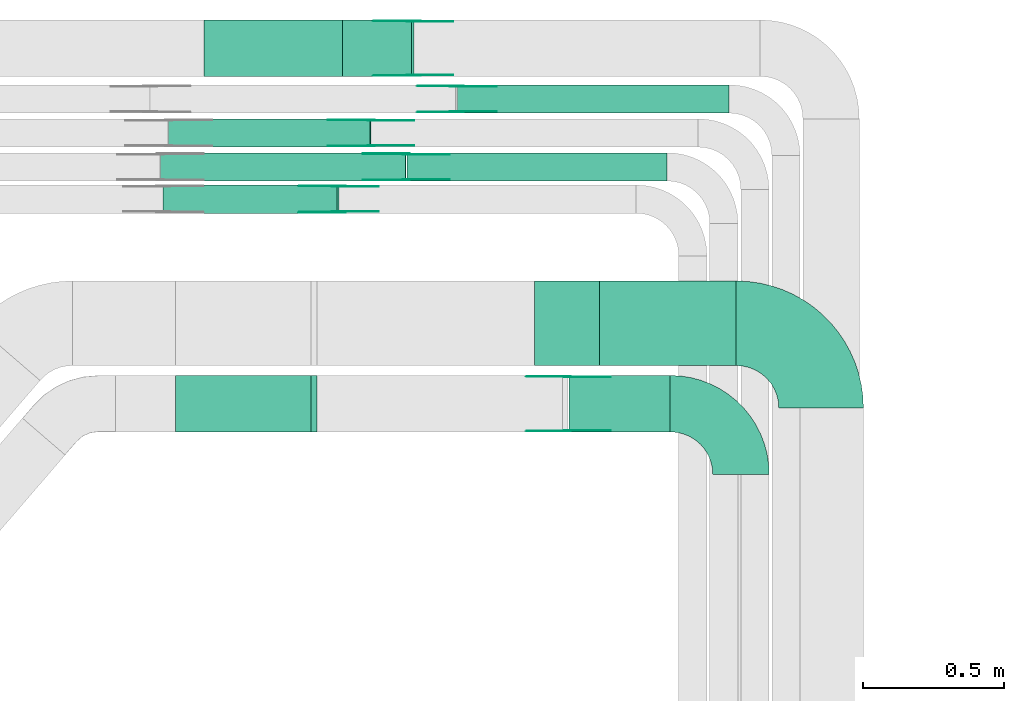
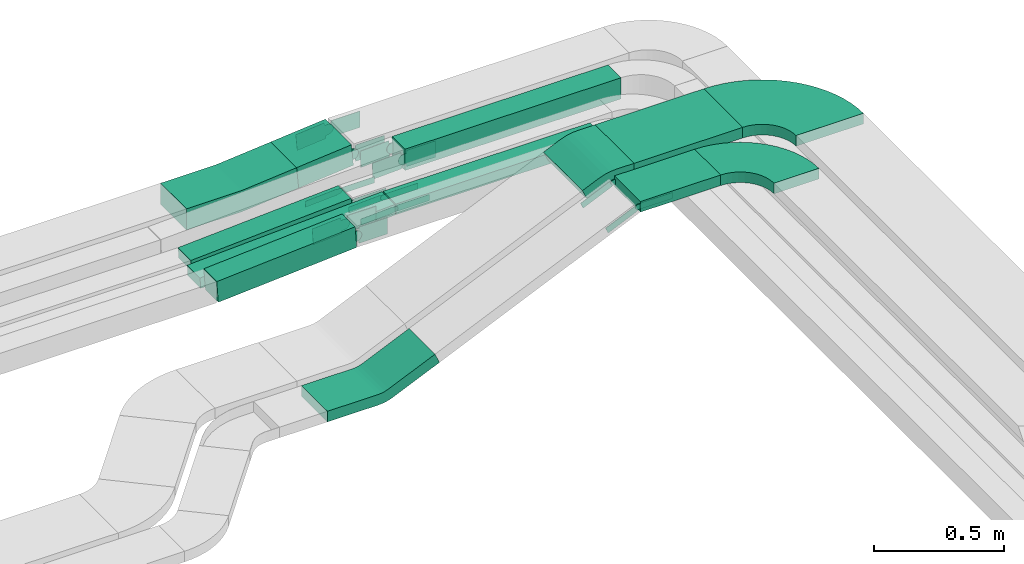
# One storey, part 21 of 28: 29 flow fittings, 8 flow segments.
"""IFC2X3 building model written with IfcOpenShell, lengths in millimetres."""

from ifc_helpers import new_model, entity, si_unit, converted_unit, derived_unit, direction, frame, frame_2d, origin, origin_2d_with_axis, place, context, subcontext, project, spatial, polyline, circle_curve, parameter, trimmed, segment, composite_curve, rectangle, outline, extrude, source, transform, mapped, material, type_object, type_shapes, element, save


model = new_model("IFC2X3")

# Units and contexts
model_context = context("Model", 3, precision=0.01, world=origin(), true_north=direction((6.12303176911189e-17, 1.0)))
body_context = subcontext(model_context, "Body", "Model", "MODEL_VIEW")
ifc_project = project(units=[si_unit("LENGTHUNIT", "METRE", prefix="MILLI"), si_unit("AREAUNIT", "SQUARE_METRE"), si_unit("VOLUMEUNIT", "CUBIC_METRE"), converted_unit("PLANEANGLEUNIT", "DEGREE", entity("IfcRatioMeasure", 0.0174532925199433), si_unit("PLANEANGLEUNIT", "RADIAN"), dimensions=[0, 0, 0, 0, 0, 0, 0]), si_unit("MASSUNIT", "GRAM", prefix="KILO"), derived_unit("MASSDENSITYUNIT", [(si_unit("MASSUNIT", "GRAM", prefix="KILO"), 1), (si_unit("LENGTHUNIT", "METRE"), -3)]), derived_unit("MOMENTOFINERTIAUNIT", [(si_unit("LENGTHUNIT", "METRE"), 4)]), si_unit("TIMEUNIT", "SECOND"), si_unit("FREQUENCYUNIT", "HERTZ"), si_unit("THERMODYNAMICTEMPERATUREUNIT", "DEGREE_CELSIUS"), derived_unit("THERMALTRANSMITTANCEUNIT", [(si_unit("MASSUNIT", "GRAM", prefix="KILO"), 1), (si_unit("THERMODYNAMICTEMPERATUREUNIT", "KELVIN"), -1), (si_unit("TIMEUNIT", "SECOND"), -3)]), derived_unit("VOLUMETRICFLOWRATEUNIT", [(si_unit("LENGTHUNIT", "METRE"), 3), (si_unit("TIMEUNIT", "SECOND"), -1)]), derived_unit("MASSFLOWRATEUNIT", [(si_unit("MASSUNIT", "GRAM", prefix="KILO"), 1), (si_unit("TIMEUNIT", "SECOND"), -1)]), derived_unit("ROTATIONALFREQUENCYUNIT", [(si_unit("TIMEUNIT", "SECOND"), -1)]), si_unit("ELECTRICCURRENTUNIT", "AMPERE"), si_unit("ELECTRICVOLTAGEUNIT", "VOLT"), si_unit("POWERUNIT", "WATT"), si_unit("FORCEUNIT", "NEWTON", prefix="KILO"), si_unit("ILLUMINANCEUNIT", "LUX"), si_unit("LUMINOUSFLUXUNIT", "LUMEN"), si_unit("LUMINOUSINTENSITYUNIT", "CANDELA"), derived_unit("USERDEFINED", [(si_unit("MASSUNIT", "GRAM", prefix="KILO"), -1), (si_unit("LENGTHUNIT", "METRE"), -2), (si_unit("TIMEUNIT", "SECOND"), 3), (si_unit("LUMINOUSFLUXUNIT", "LUMEN"), 1)]), derived_unit("LINEARVELOCITYUNIT", [(si_unit("LENGTHUNIT", "METRE"), 1), (si_unit("TIMEUNIT", "SECOND"), -1)]), si_unit("PRESSUREUNIT", "PASCAL"), derived_unit("USERDEFINED", [(si_unit("LENGTHUNIT", "METRE"), -2), (si_unit("MASSUNIT", "GRAM", prefix="KILO"), 1), (si_unit("TIMEUNIT", "SECOND"), -2)]), derived_unit("LINEARFORCEUNIT", [(si_unit("MASSUNIT", "GRAM", prefix="KILO"), 1), (si_unit("LENGTHUNIT", "METRE"), 1), (si_unit("TIMEUNIT", "SECOND"), -2), (si_unit("LENGTHUNIT", "METRE"), -1)]), derived_unit("PLANARFORCEUNIT", [(si_unit("MASSUNIT", "GRAM", prefix="KILO"), 1), (si_unit("LENGTHUNIT", "METRE"), 1), (si_unit("TIMEUNIT", "SECOND"), -2), (si_unit("LENGTHUNIT", "METRE"), -2)])], contexts=[model_context])

# Site, building, storey
site_placement = place(None, origin())
site = spatial("IfcSite", under=ifc_project, at=site_placement, CompositionType="ELEMENT")
building_placement = place(site_placement, origin())
building = spatial("IfcBuilding", under=site, at=building_placement, CompositionType="ELEMENT")
storey_placement = place(building_placement, frame((0.0, 0.0, 15900.0)))
storey = spatial("IfcBuildingStorey", under=building, at=storey_placement, CompositionType="ELEMENT", Elevation=15900.0)

# Flow segments
cable_carrier_segment_type = type_object("IfcCableCarrierSegmentType", PredefinedType="CABLETRAYSEGMENT")
flow_segment_1_placement = place(storey_placement, frame((59341.75, 15869.99, 2660.0)))
element("IfcFlowSegment", 1, at=flow_segment_1_placement, inside=storey, type_object=cable_carrier_segment_type, context=body_context, shape_type="SweptSolid", body=[
    extrude(rectangle(XDim=963.323442098033, YDim=99.9999999999989, at=origin_2d_with_axis()), frame((481.66, 50.0, 0.0), z_axis=(0.0, 0.0, 1.0), x_axis=(-1.0, 0.0, 0.0)), (0.0, 0.0, 1.0), 99.9999999999989),
])
flow_segment_2_placement = place(storey_placement, frame((59162.38, 15629.46, 2660.19)))
element("IfcFlowSegment", 2, at=flow_segment_2_placement, inside=storey, type_object=cable_carrier_segment_type, context=body_context, shape_type="SweptSolid", body=[
    extrude(rectangle(XDim=922.700351153026, YDim=99.9999999999989, at=origin_2d_with_axis()), frame((461.35, 50.0, 0.0), z_axis=(0.0, 0.0, 1.0), x_axis=(-1.0, 0.0, 0.0)), (0.0, 0.0, 1.0), 50.0000000000016),
])
flow_segment_3_placement = place(storey_placement, frame((58933.89, 15999.99, 2637.69)))
element("IfcFlowSegment", 3, at=flow_segment_3_placement, inside=storey, type_object=cable_carrier_segment_type, context=body_context, shape_type="SweptSolid", body=[
    extrude(rectangle(XDim=100.000000000003, YDim=200.000000000002, at=frame_2d((0.0, 0.0), x_axis=(0.0, 1.0))), frame((4.53, 100.0, 49.79), z_axis=(0.995891337468723, 0.0, 0.0905563026782642), x_axis=(0.0, 1.0, 0.0)), (0.0, 0.0, 1.0), 245.232289969506),
])
flow_segment_4_placement = place(storey_placement, frame((58297.9, 15514.99, 2617.34)))
element("IfcFlowSegment", 4, at=flow_segment_4_placement, inside=storey, type_object=cable_carrier_segment_type, context=body_context, shape_type="SweptSolid", body=[
    extrude(rectangle(XDim=100.0, YDim=99.9999999999989, at=origin_2d_with_axis()), frame((3.44, 50.0, 49.88), z_axis=(0.997626423978678, 0.0, 0.068858682673394), x_axis=(-0.068858682673394, 0.0, 0.997626423978678)), (0.0, 0.0, 1.0), 618.350729393012),
])
flow_segment_5_placement = place(storey_placement, frame((58318.19, 15749.46, 2617.52)))
element("IfcFlowSegment", 5, at=flow_segment_5_placement, inside=storey, type_object=cable_carrier_segment_type, context=body_context, shape_type="SweptSolid", body=[
    extrude(rectangle(XDim=50.0000000000018, YDim=99.9999999999989, at=frame_2d((0.0, 0.0), x_axis=(0.0, 1.0))), frame((1.49, 50.0, 24.96), z_axis=(0.998226574623021, 0.0, 0.0595290325504308), x_axis=(0.0, 1.0, 0.0)), (0.0, 0.0, 1.0), 715.803609284785),
])
flow_segment_6_placement = place(storey_placement, frame((58289.55, 15629.46, 2617.48)))
element("IfcFlowSegment", 6, at=flow_segment_6_placement, inside=storey, type_object=cable_carrier_segment_type, context=body_context, shape_type="SweptSolid", body=[
    extrude(rectangle(XDim=49.9999999999996, YDim=99.9999999999989, at=frame_2d((0.0, 0.0), x_axis=(0.0, 1.0))), frame((1.23, 50.0, 24.97), z_axis=(0.998794992173113, 0.0, 0.0490771190058262), x_axis=(0.0, 1.0, 0.0)), (0.0, 0.0, 1.0), 869.220832372037),
])
flow_segment_7_placement = place(storey_placement, frame((59737.94, 14740.03, 3010.0)))
element("IfcFlowSegment", 7, at=flow_segment_7_placement, inside=storey, type_object=cable_carrier_segment_type, context=body_context, shape_type="SweptSolid", body=[
    extrude(rectangle(XDim=357.878829425625, YDim=199.999999999998, at=origin_2d_with_axis()), frame((178.94, 100.0, 0.0), z_axis=(0.0, 0.0, 1.0), x_axis=(-1.0, 0.0, 0.0)), (0.0, 0.0, 1.0), 50.0000000000016),
])
flow_segment_8_placement = place(storey_placement, frame((59845.66, 14975.03, 3010.0)))
element("IfcFlowSegment", 8, at=flow_segment_8_placement, inside=storey, type_object=cable_carrier_segment_type, context=body_context, shape_type="SweptSolid", body=[
    extrude(rectangle(XDim=484.15332319662, YDim=300.000000000001, at=origin_2d_with_axis()), frame((242.08, 150.0, 0.0), z_axis=(0.0, 0.0, 1.0), x_axis=(-1.0, 0.0, 0.0)), (0.0, 0.0, 1.0), 50.0000000000016),
])

# Flow fittings
ifc_material_1 = material()
cable_carrier_fitting_type_1 = type_object("IfcCableCarrierFittingType", Name="470_DKC_S5_Variable Angle Elbow 0-45:-", PredefinedType="NOTDEFINED", material=ifc_material_1)
shared_shape_1 = source(origin(), body_context, "Body", "SweptSolid", [
    extrude(outline(composite_curve([segment(polyline([(-150.75, -300.25), (-149.75, -300.25)]), True, "CONTINUOUS"), segment(trimmed(circle_curve(frame_2d((-149.75, 149.75), x_axis=(0.0, -1.0)), 450.0), [parameter(0.0)], [parameter(90.0000000000001)], True, "PARAMETER"), True, "CONTINUOUS"), segment(polyline([(300.25, 149.75), (300.25, 150.75)]), True, "CONTINUOUS"), segment(polyline([(300.25, 150.75), (0.25, 150.75)]), True, "CONTINUOUS"), segment(polyline([(0.25, 150.75), (0.25, 149.75)]), True, "CONTINUOUS"), segment(trimmed(circle_curve(frame_2d((-149.75, 149.75), x_axis=(0.0, -1.0)), 150.0), [parameter(0.0)], [parameter(90.0000000000001)], True, "PARAMETER"), False, "CONTINUOUS"), segment(polyline([(-149.75, -0.25), (-150.75, -0.25)]), True, "CONTINUOUS"), segment(polyline([(-150.75, -0.25), (-150.75, -300.25)]), True, "CONTINUOUS")], self_intersect=False)), frame((-150.25, 150.25, -25.0)), (0.0, 0.0, 1.0), 49.9999999999974),
])
type_shapes(cable_carrier_fitting_type_1, [shared_shape_1])
flow_fitting_1_placement = place(storey_placement, frame((60630.82, 15125.03, 3035.0), z_axis=(0.0, 0.0, 1.0), x_axis=(0.0, 1.0, 0.0)))
element("IfcFlowFitting", 9, at=flow_fitting_1_placement, inside=storey, type_object=cable_carrier_fitting_type_1, material=ifc_material_1, Name="470_DKC_S5_Variable Angle Elbow 0-45:-", ObjectType="470_DKC_S5_Variable Angle Elbow 0-45:-", context=body_context, shape_type="MappedRepresentation", body=[
    mapped(shared_shape_1, transform((0.0, 0.0, 0.0), scale=1.0)),
])
ifc_material_2 = material(Name="G")
cable_carrier_fitting_type_2 = type_object("IfcCableCarrierFittingType", PredefinedType="NOTDEFINED", material=ifc_material_2)
shared_shape_2 = source(origin(), body_context, "Body", "SweptSolid", [
    extrude(outline(composite_curve([segment(trimmed(circle_curve(frame_2d((-44.59, 0.0), x_axis=(1.0, 0.0)), 12.5), [parameter(90.0000000000007)], [parameter(270.0)], True, "PARAMETER"), True, "CONTINUOUS"), segment(polyline([(-44.59, -12.5), (-33.09, -12.5)]), True, "CONTINUOUS"), segment(polyline([(-33.09, -12.5), (-31.23, -14.5)]), True, "CONTINUOUS"), segment(polyline([(-31.23, -14.5), (108.91, -14.5)]), True, "CONTINUOUS"), segment(polyline([(108.91, -14.5), (108.91, 14.5)]), True, "CONTINUOUS"), segment(polyline([(108.91, 14.5), (-31.23, 14.5)]), True, "CONTINUOUS"), segment(polyline([(-31.23, 14.5), (-33.09, 12.5)]), True, "CONTINUOUS"), segment(polyline([(-33.09, 12.5), (-44.59, 12.5)]), True, "CONTINUOUS")], self_intersect=False)), frame((44.59, 0.0, 0.0), z_axis=(0.0, 0.0, -1.0), x_axis=(1.0, 0.0, 0.0)), (0.0, 0.0, -1.0), 2.0),
])
type_shapes(cable_carrier_fitting_type_2, [shared_shape_2])
flow_fitting_2_placement = place(storey_placement, frame((59036.08, 15754.0, 2685.2), z_axis=(0.0, -1.0, 0.0), x_axis=(-0.998226574623013, 0.0, -0.0595290325505655)))
element("IfcFlowFitting", 10, at=flow_fitting_2_placement, inside=storey, type_object=cable_carrier_fitting_type_2, material=ifc_material_2, context=body_context, shape_type="MappedRepresentation", body=[
    mapped(shared_shape_2, transform((0.0, 0.0, 0.0), scale=1.0)),
])
cable_carrier_fitting_type_3 = type_object("IfcCableCarrierFittingType", PredefinedType="NOTDEFINED", material=ifc_material_2)
type_shapes(cable_carrier_fitting_type_3, [shared_shape_2])
flow_fitting_3_placement = place(storey_placement, frame((59036.08, 15842.92, 2685.2), z_axis=(0.0, 1.0, 0.0), x_axis=(1.0, 0.0, 0.0)))
element("IfcFlowFitting", 11, at=flow_fitting_3_placement, inside=storey, type_object=cable_carrier_fitting_type_3, material=ifc_material_2, context=body_context, shape_type="MappedRepresentation", body=[
    mapped(shared_shape_2, transform((0.0, 0.0, 0.0), scale=1.0)),
])
flow_fitting_4_placement = place(storey_placement, frame((59160.66, 15634.0, 2685.19), z_axis=(0.0, -1.0, 0.0), x_axis=(-0.998794992173109, 0.0, -0.0490771190058922)))
element("IfcFlowFitting", 12, at=flow_fitting_4_placement, inside=storey, type_object=cable_carrier_fitting_type_2, material=ifc_material_2, context=body_context, shape_type="MappedRepresentation", body=[
    mapped(shared_shape_2, transform((0.0, 0.0, 0.0), scale=1.0)),
])
flow_fitting_5_placement = place(storey_placement, frame((59160.66, 15722.92, 2685.19), z_axis=(0.0, 1.0, 0.0), x_axis=(1.0, 0.0, 0.0)))
element("IfcFlowFitting", 13, at=flow_fitting_5_placement, inside=storey, type_object=cable_carrier_fitting_type_3, material=ifc_material_2, context=body_context, shape_type="MappedRepresentation", body=[
    mapped(shared_shape_2, transform((0.0, 0.0, 0.0), scale=1.0)),
])
flow_fitting_6_placement = place(storey_placement, frame((59730.82, 14744.57, 3035.0), z_axis=(0.0, -1.0, 0.0), x_axis=(-0.914695360334433, 0.0, -0.404144030987297)))
element("IfcFlowFitting", 14, at=flow_fitting_6_placement, inside=storey, type_object=cable_carrier_fitting_type_2, material=ifc_material_2, context=body_context, shape_type="MappedRepresentation", body=[
    mapped(shared_shape_2, transform((0.0, 0.0, 0.0), scale=1.0)),
])
flow_fitting_7_placement = place(storey_placement, frame((59730.82, 14933.49, 3035.0), z_axis=(0.0, 1.0, 0.0), x_axis=(1.0, 0.0, 0.0)))
element("IfcFlowFitting", 15, at=flow_fitting_7_placement, inside=storey, type_object=cable_carrier_fitting_type_3, material=ifc_material_2, context=body_context, shape_type="MappedRepresentation", body=[
    mapped(shared_shape_2, transform((0.0, 0.0, 0.0), scale=1.0)),
])
cable_carrier_fitting_type_4 = type_object("IfcCableCarrierFittingType", PredefinedType="NOTDEFINED", material=ifc_material_2)
shared_shape_3 = source(origin(), body_context, "Body", "SweptSolid", [
    extrude(outline(composite_curve([segment(trimmed(circle_curve(frame_2d((-44.59, 0.0), x_axis=(1.0, 0.0)), 12.5), [parameter(90.0000000000007)], [parameter(270.0)], True, "PARAMETER"), True, "CONTINUOUS"), segment(polyline([(-44.59, -12.5), (-33.09, -12.5)]), True, "CONTINUOUS"), segment(polyline([(-33.09, -12.5), (-31.23, -14.5)]), True, "CONTINUOUS"), segment(polyline([(-31.23, -14.5), (108.91, -14.5)]), True, "CONTINUOUS"), segment(polyline([(108.91, -14.5), (108.91, 14.5)]), True, "CONTINUOUS"), segment(polyline([(108.91, 14.5), (-31.23, 14.5)]), True, "CONTINUOUS"), segment(polyline([(-31.23, 14.5), (-33.09, 12.5)]), True, "CONTINUOUS"), segment(polyline([(-33.09, 12.5), (-44.59, 12.5)]), True, "CONTINUOUS")], self_intersect=False)), frame((44.59, 0.0, 0.0)), (0.0, 0.0, 1.0), 2.0),
])
type_shapes(cable_carrier_fitting_type_4, [shared_shape_3])
flow_fitting_8_placement = place(storey_placement, frame((59036.08, 15844.92, 2685.2), z_axis=(0.0, 1.0, 0.0), x_axis=(-0.998226574623013, 0.0, -0.0595290325505655)))
element("IfcFlowFitting", 16, at=flow_fitting_8_placement, inside=storey, type_object=cable_carrier_fitting_type_4, material=ifc_material_2, context=body_context, shape_type="MappedRepresentation", body=[
    mapped(shared_shape_3, transform((0.0, 0.0, 0.0), scale=1.0)),
])
cable_carrier_fitting_type_5 = type_object("IfcCableCarrierFittingType", PredefinedType="NOTDEFINED", material=ifc_material_2)
type_shapes(cable_carrier_fitting_type_5, [shared_shape_3])
flow_fitting_9_placement = place(storey_placement, frame((59036.08, 15756.0, 2685.2), z_axis=(0.0, -1.0, 0.0), x_axis=(1.0, 0.0, 0.0)))
element("IfcFlowFitting", 17, at=flow_fitting_9_placement, inside=storey, type_object=cable_carrier_fitting_type_5, material=ifc_material_2, context=body_context, shape_type="MappedRepresentation", body=[
    mapped(shared_shape_3, transform((0.0, 0.0, 0.0), scale=1.0)),
])
flow_fitting_10_placement = place(storey_placement, frame((59160.66, 15724.92, 2685.19), z_axis=(0.0, 1.0, 0.0), x_axis=(-0.998794992173109, 0.0, -0.0490771190058922)))
element("IfcFlowFitting", 18, at=flow_fitting_10_placement, inside=storey, type_object=cable_carrier_fitting_type_4, material=ifc_material_2, context=body_context, shape_type="MappedRepresentation", body=[
    mapped(shared_shape_3, transform((0.0, 0.0, 0.0), scale=1.0)),
])
flow_fitting_11_placement = place(storey_placement, frame((59160.66, 15636.0, 2685.19), z_axis=(0.0, -1.0, 0.0), x_axis=(1.0, 0.0, 0.0)))
element("IfcFlowFitting", 19, at=flow_fitting_11_placement, inside=storey, type_object=cable_carrier_fitting_type_5, material=ifc_material_2, context=body_context, shape_type="MappedRepresentation", body=[
    mapped(shared_shape_3, transform((0.0, 0.0, 0.0), scale=1.0)),
])
flow_fitting_12_placement = place(storey_placement, frame((59730.82, 14935.49, 3035.0), z_axis=(0.0, 1.0, 0.0), x_axis=(-0.914695360334433, 0.0, -0.404144030987297)))
element("IfcFlowFitting", 20, at=flow_fitting_12_placement, inside=storey, type_object=cable_carrier_fitting_type_4, material=ifc_material_2, context=body_context, shape_type="MappedRepresentation", body=[
    mapped(shared_shape_3, transform((0.0, 0.0, 0.0), scale=1.0)),
])
flow_fitting_13_placement = place(storey_placement, frame((59730.82, 14746.57, 3035.0), z_axis=(0.0, -1.0, 0.0), x_axis=(1.0, 0.0, 0.0)))
element("IfcFlowFitting", 21, at=flow_fitting_13_placement, inside=storey, type_object=cable_carrier_fitting_type_5, material=ifc_material_2, context=body_context, shape_type="MappedRepresentation", body=[
    mapped(shared_shape_3, transform((0.0, 0.0, 0.0), scale=1.0)),
])
cable_carrier_fitting_type_6 = type_object("IfcCableCarrierFittingType", Name="470_DKC_S5_Variable Angle Elbow 0-45:-", PredefinedType="NOTDEFINED", material=ifc_material_1)
shared_shape_4 = source(origin(), body_context, "Body", "SweptSolid", [
    extrude(outline(composite_curve([segment(polyline([(-125.75, -225.25), (-124.75, -225.25)]), True, "CONTINUOUS"), segment(trimmed(circle_curve(frame_2d((-124.75, 124.75), x_axis=(0.0, -1.0)), 350.0), [parameter(0.0)], [parameter(90.0)], True, "PARAMETER"), True, "CONTINUOUS"), segment(polyline([(225.25, 124.75), (225.25, 125.75)]), True, "CONTINUOUS"), segment(polyline([(225.25, 125.75), (25.25, 125.75)]), True, "CONTINUOUS"), segment(polyline([(25.25, 125.75), (25.25, 124.75)]), True, "CONTINUOUS"), segment(trimmed(circle_curve(frame_2d((-124.75, 124.75), x_axis=(0.0, -1.0)), 150.0), [parameter(0.0)], [parameter(90.0)], True, "PARAMETER"), False, "CONTINUOUS"), segment(polyline([(-124.75, -25.25), (-125.75, -25.25)]), True, "CONTINUOUS"), segment(polyline([(-125.75, -25.25), (-125.75, -225.25)]), True, "CONTINUOUS")], self_intersect=False)), frame((-125.25, 125.25, -25.0)), (0.0, 0.0, 1.0), 50.000000000001),
])
type_shapes(cable_carrier_fitting_type_6, [shared_shape_4])
flow_fitting_14_placement = place(storey_placement, frame((60346.82, 14840.03, 3035.0), z_axis=(0.0, 0.0, 1.0), x_axis=(0.0, 1.0, 0.0)))
element("IfcFlowFitting", 22, at=flow_fitting_14_placement, inside=storey, type_object=cable_carrier_fitting_type_6, material=ifc_material_1, Name="470_DKC_S5_Variable Angle Elbow 0-45:-", ObjectType="470_DKC_S5_Variable Angle Elbow 0-45:-", context=body_context, shape_type="MappedRepresentation", body=[
    mapped(shared_shape_4, transform((0.0, 0.0, 0.0), scale=1.0)),
])
cable_carrier_fitting_type_7 = type_object("IfcCableCarrierFittingType", PredefinedType="NOTDEFINED", material=ifc_material_2)
shared_shape_5 = source(origin(), body_context, "Body", "SweptSolid", [
    extrude(outline(composite_curve([segment(trimmed(circle_curve(frame_2d((-41.47, 0.0), x_axis=(1.0, 0.0)), 25.0), [parameter(90.0000000000007)], [parameter(270.0)], True, "PARAMETER"), True, "CONTINUOUS"), segment(polyline([(-41.47, -25.0), (-29.97, -25.0)]), True, "CONTINUOUS"), segment(polyline([(-29.97, -25.0), (-28.1, -38.5)]), True, "CONTINUOUS"), segment(polyline([(-28.1, -38.5), (99.53, -38.5)]), True, "CONTINUOUS"), segment(polyline([(99.53, -38.5), (99.53, 38.5)]), True, "CONTINUOUS"), segment(polyline([(99.53, 38.5), (-28.1, 38.5)]), True, "CONTINUOUS"), segment(polyline([(-28.1, 38.5), (-29.97, 25.0)]), True, "CONTINUOUS"), segment(polyline([(-29.97, 25.0), (-41.47, 25.0)]), True, "CONTINUOUS")], self_intersect=False)), frame((41.47, 0.0, 0.0), z_axis=(0.0, 0.0, -1.0), x_axis=(1.0, 0.0, 0.0)), (0.0, 0.0, -1.0), 2.0),
])
type_shapes(cable_carrier_fitting_type_7, [shared_shape_5])
flow_fitting_15_placement = place(storey_placement, frame((58921.08, 15519.53, 2710.0), z_axis=(0.0, -1.0, 0.0), x_axis=(-0.997626423978682, 0.0, -0.0688586826733382)))
element("IfcFlowFitting", 23, at=flow_fitting_15_placement, inside=storey, type_object=cable_carrier_fitting_type_7, material=ifc_material_2, context=body_context, shape_type="MappedRepresentation", body=[
    mapped(shared_shape_5, transform((0.0, 0.0, 0.0), scale=1.0)),
])
cable_carrier_fitting_type_8 = type_object("IfcCableCarrierFittingType", PredefinedType="NOTDEFINED", material=ifc_material_2)
type_shapes(cable_carrier_fitting_type_8, [shared_shape_5])
flow_fitting_16_placement = place(storey_placement, frame((58921.08, 15608.45, 2710.0), z_axis=(0.0, 1.0, 0.0), x_axis=(1.0, 0.0, 0.0)))
element("IfcFlowFitting", 24, at=flow_fitting_16_placement, inside=storey, type_object=cable_carrier_fitting_type_8, material=ifc_material_2, context=body_context, shape_type="MappedRepresentation", body=[
    mapped(shared_shape_5, transform((0.0, 0.0, 0.0), scale=1.0)),
])
flow_fitting_17_placement = place(storey_placement, frame((59339.64, 15874.53, 2710.0), z_axis=(0.0, -1.0, 0.0), x_axis=(-0.999143050018218, 0.0, -0.0413904046886741)))
element("IfcFlowFitting", 25, at=flow_fitting_17_placement, inside=storey, type_object=cable_carrier_fitting_type_7, material=ifc_material_2, context=body_context, shape_type="MappedRepresentation", body=[
    mapped(shared_shape_5, transform((0.0, 0.0, 0.0), scale=1.0)),
])
flow_fitting_18_placement = place(storey_placement, frame((59339.64, 15963.45, 2710.0), z_axis=(0.0, 1.0, 0.0), x_axis=(1.0, 0.0, 0.0)))
element("IfcFlowFitting", 26, at=flow_fitting_18_placement, inside=storey, type_object=cable_carrier_fitting_type_8, material=ifc_material_2, context=body_context, shape_type="MappedRepresentation", body=[
    mapped(shared_shape_5, transform((0.0, 0.0, 0.0), scale=1.0)),
])
flow_fitting_19_placement = place(storey_placement, frame((59186.08, 16004.53, 2710.0), z_axis=(0.0, -1.0, 0.0), x_axis=(-0.995891337468728, 0.0, -0.0905563026782111)))
element("IfcFlowFitting", 27, at=flow_fitting_19_placement, inside=storey, type_object=cable_carrier_fitting_type_7, material=ifc_material_2, context=body_context, shape_type="MappedRepresentation", body=[
    mapped(shared_shape_5, transform((0.0, 0.0, 0.0), scale=1.0)),
])
flow_fitting_20_placement = place(storey_placement, frame((59186.08, 16193.45, 2710.0), z_axis=(0.0, 1.0, 0.0), x_axis=(1.0, 0.0, 0.0)))
element("IfcFlowFitting", 28, at=flow_fitting_20_placement, inside=storey, type_object=cable_carrier_fitting_type_8, material=ifc_material_2, context=body_context, shape_type="MappedRepresentation", body=[
    mapped(shared_shape_5, transform((0.0, 0.0, 0.0), scale=1.0)),
])
cable_carrier_fitting_type_9 = type_object("IfcCableCarrierFittingType", PredefinedType="NOTDEFINED", material=ifc_material_2)
shared_shape_6 = source(origin(), body_context, "Body", "SweptSolid", [
    extrude(outline(composite_curve([segment(trimmed(circle_curve(frame_2d((-41.47, 0.0), x_axis=(1.0, 0.0)), 25.0), [parameter(90.0000000000007)], [parameter(270.0)], True, "PARAMETER"), True, "CONTINUOUS"), segment(polyline([(-41.47, -25.0), (-29.97, -25.0)]), True, "CONTINUOUS"), segment(polyline([(-29.97, -25.0), (-28.1, -38.5)]), True, "CONTINUOUS"), segment(polyline([(-28.1, -38.5), (99.53, -38.5)]), True, "CONTINUOUS"), segment(polyline([(99.53, -38.5), (99.53, 38.5)]), True, "CONTINUOUS"), segment(polyline([(99.53, 38.5), (-28.1, 38.5)]), True, "CONTINUOUS"), segment(polyline([(-28.1, 38.5), (-29.97, 25.0)]), True, "CONTINUOUS"), segment(polyline([(-29.97, 25.0), (-41.47, 25.0)]), True, "CONTINUOUS")], self_intersect=False)), frame((41.47, 0.0, 0.0)), (0.0, 0.0, 1.0), 2.0),
])
type_shapes(cable_carrier_fitting_type_9, [shared_shape_6])
flow_fitting_21_placement = place(storey_placement, frame((58921.08, 15610.45, 2710.0), z_axis=(0.0, 1.0, 0.0), x_axis=(-0.997626423978682, 0.0, -0.0688586826733382)))
element("IfcFlowFitting", 29, at=flow_fitting_21_placement, inside=storey, type_object=cable_carrier_fitting_type_9, material=ifc_material_2, context=body_context, shape_type="MappedRepresentation", body=[
    mapped(shared_shape_6, transform((0.0, 0.0, 0.0), scale=1.0)),
])
cable_carrier_fitting_type_10 = type_object("IfcCableCarrierFittingType", PredefinedType="NOTDEFINED", material=ifc_material_2)
type_shapes(cable_carrier_fitting_type_10, [shared_shape_6])
flow_fitting_22_placement = place(storey_placement, frame((58921.08, 15521.53, 2710.0), z_axis=(0.0, -1.0, 0.0), x_axis=(1.0, 0.0, 0.0)))
element("IfcFlowFitting", 30, at=flow_fitting_22_placement, inside=storey, type_object=cable_carrier_fitting_type_10, material=ifc_material_2, context=body_context, shape_type="MappedRepresentation", body=[
    mapped(shared_shape_6, transform((0.0, 0.0, 0.0), scale=1.0)),
])
flow_fitting_23_placement = place(storey_placement, frame((59339.64, 15965.45, 2710.0), z_axis=(0.0, 1.0, 0.0), x_axis=(-0.999143050018218, 0.0, -0.0413904046886741)))
element("IfcFlowFitting", 31, at=flow_fitting_23_placement, inside=storey, type_object=cable_carrier_fitting_type_9, material=ifc_material_2, context=body_context, shape_type="MappedRepresentation", body=[
    mapped(shared_shape_6, transform((0.0, 0.0, 0.0), scale=1.0)),
])
flow_fitting_24_placement = place(storey_placement, frame((59339.64, 15876.53, 2710.0), z_axis=(0.0, -1.0, 0.0), x_axis=(1.0, 0.0, 0.0)))
element("IfcFlowFitting", 32, at=flow_fitting_24_placement, inside=storey, type_object=cable_carrier_fitting_type_10, material=ifc_material_2, context=body_context, shape_type="MappedRepresentation", body=[
    mapped(shared_shape_6, transform((0.0, 0.0, 0.0), scale=1.0)),
])
flow_fitting_25_placement = place(storey_placement, frame((59186.08, 16195.45, 2710.0), z_axis=(0.0, 1.0, 0.0), x_axis=(-0.995891337468728, 0.0, -0.0905563026782111)))
element("IfcFlowFitting", 33, at=flow_fitting_25_placement, inside=storey, type_object=cable_carrier_fitting_type_9, material=ifc_material_2, context=body_context, shape_type="MappedRepresentation", body=[
    mapped(shared_shape_6, transform((0.0, 0.0, 0.0), scale=1.0)),
])
flow_fitting_26_placement = place(storey_placement, frame((59186.08, 16006.53, 2710.0), z_axis=(0.0, -1.0, 0.0), x_axis=(1.0, 0.0, 0.0)))
element("IfcFlowFitting", 34, at=flow_fitting_26_placement, inside=storey, type_object=cable_carrier_fitting_type_10, material=ifc_material_2, context=body_context, shape_type="MappedRepresentation", body=[
    mapped(shared_shape_6, transform((0.0, 0.0, 0.0), scale=1.0)),
])
cable_carrier_fitting_type_11 = type_object("IfcCableCarrierFittingType", Name="470_DKC_S5_CS 90 internal vertical angle:-", PredefinedType="NOTDEFINED", material=ifc_material_1)
shared_shape_7 = source(origin(), body_context, "Body", "SweptSolid", [
    extrude(outline(composite_curve([segment(polyline([(-247.98, -55.79), (-7.22, -55.79)]), True, "CONTINUOUS"), segment(trimmed(circle_curve(frame_2d((-7.22, 159.21), x_axis=(0.0, -1.0)), 214.999999999999), [parameter(0.0)], [parameter(5.19561157426616)], True, "PARAMETER"), True, "CONTINUOUS"), segment(polyline([(12.25, -54.91), (252.02, -33.1)]), True, "CONTINUOUS"), segment(polyline([(252.02, -33.1), (242.96, 66.49)]), True, "CONTINUOUS"), segment(polyline([(242.96, 66.49), (3.19, 44.68)]), True, "CONTINUOUS"), segment(trimmed(circle_curve(frame_2d((-7.22, 159.21), x_axis=(0.0, -1.0)), 114.999999999999), [parameter(0.0)], [parameter(5.19561157426616)], True, "PARAMETER"), False, "CONTINUOUS"), segment(polyline([(-7.22, 44.21), (-247.98, 44.21)]), True, "CONTINUOUS"), segment(polyline([(-247.98, 44.21), (-247.98, -55.79)]), True, "CONTINUOUS")], self_intersect=False)), frame((-0.26, 5.79, -100.0)), (0.0, 0.0, 1.0), 200.0),
])
type_shapes(cable_carrier_fitting_type_11, [shared_shape_7])
flow_fitting_27_placement = place(storey_placement, frame((58691.19, 16099.99, 2665.0), z_axis=(0.0, -1.0, 0.0), x_axis=(1.0, 0.0, 0.0)))
element("IfcFlowFitting", 35, at=flow_fitting_27_placement, inside=storey, type_object=cable_carrier_fitting_type_11, material=ifc_material_1, Name="470_DKC_S5_CS 90 internal vertical angle:-", ObjectType="470_DKC_S5_CS 90 internal vertical angle:-", context=body_context, shape_type="MappedRepresentation", body=[
    mapped(shared_shape_7, transform((0.0, 0.0, 0.0), scale=1.0)),
])
cable_carrier_fitting_type_12 = type_object("IfcCableCarrierFittingType", Name="470_DKC_S5_CD 90 external vertical angle:-", PredefinedType="NOTDEFINED", material=ifc_material_1)
shared_shape_8 = source(origin(), body_context, "Body", "SweptSolid", [
    extrude(outline(composite_curve([segment(polyline([(-111.65, -40.12), (-31.64, -40.12)]), True, "CONTINUOUS"), segment(trimmed(circle_curve(frame_2d((-31.64, 149.88), x_axis=(0.0, -1.0)), 189.999999999999), [parameter(0.0)], [parameter(23.8374988354048)], True, "PARAMETER"), True, "CONTINUOUS"), segment(polyline([(45.15, -23.91), (118.35, 8.42)]), True, "CONTINUOUS"), segment(polyline([(118.35, 8.42), (98.14, 54.16)]), True, "CONTINUOUS"), segment(polyline([(98.14, 54.16), (24.94, 21.82)]), True, "CONTINUOUS"), segment(trimmed(circle_curve(frame_2d((-31.64, 149.88), x_axis=(0.0, -1.0)), 139.999999999999), [parameter(0.0)], [parameter(23.8374988354048)], True, "PARAMETER"), False, "CONTINUOUS"), segment(polyline([(-31.64, 9.88), (-111.65, 9.88)]), True, "CONTINUOUS"), segment(polyline([(-111.65, 9.88), (-111.65, -40.12)]), True, "CONTINUOUS")], self_intersect=False)), frame((-3.19, 15.12, -150.0)), (0.0, 0.0, 1.0), 300.0),
])
type_shapes(cable_carrier_fitting_type_12, [shared_shape_8])
flow_fitting_28_placement = place(storey_placement, frame((59730.82, 15125.03, 3035.0), z_axis=(0.0, -1.0, 0.0), x_axis=(-1.0, 0.0, 0.0)))
element("IfcFlowFitting", 36, at=flow_fitting_28_placement, inside=storey, type_object=cable_carrier_fitting_type_12, material=ifc_material_1, Name="470_DKC_S5_CD 90 external vertical angle:-", ObjectType="470_DKC_S5_CD 90 external vertical angle:-", context=body_context, shape_type="MappedRepresentation", body=[
    mapped(shared_shape_8, transform((0.0, 0.0, 0.0), scale=1.0)),
])
cable_carrier_fitting_type_13 = type_object("IfcCableCarrierFittingType", Name="470_DKC_S5_CS 90 internal vertical angle:-", PredefinedType="NOTDEFINED", material=ifc_material_1)
shared_shape_9 = source(origin(), body_context, "Body", "SweptSolid", [
    extrude(outline(composite_curve([segment(polyline([(-249.77, -53.84), (-23.46, -53.84)]), True, "CONTINUOUS"), segment(trimmed(circle_curve(frame_2d((-23.46, 111.16), x_axis=(0.0, -1.0)), 164.999999999999), [parameter(0.0)], [parameter(23.8374988354359)], True, "PARAMETER"), True, "CONTINUOUS"), segment(polyline([(43.22, -39.76), (250.23, 51.7)]), True, "CONTINUOUS"), segment(polyline([(250.23, 51.7), (230.02, 97.44)]), True, "CONTINUOUS"), segment(polyline([(230.02, 97.44), (23.01, 5.97)]), True, "CONTINUOUS"), segment(trimmed(circle_curve(frame_2d((-23.46, 111.16), x_axis=(0.0, -1.0)), 114.999999999999), [parameter(0.0)], [parameter(23.8374988354359)], True, "PARAMETER"), False, "CONTINUOUS"), segment(polyline([(-23.46, -3.84), (-249.77, -3.84)]), True, "CONTINUOUS"), segment(polyline([(-249.77, -3.84), (-249.77, -53.84)]), True, "CONTINUOUS")], self_intersect=False)), frame((-6.09, 28.84, -100.0)), (0.0, 0.0, 1.0), 200.0),
])
type_shapes(cable_carrier_fitting_type_13, [shared_shape_9])
flow_fitting_29_placement = place(storey_placement, frame((58599.17, 14840.03, 2535.0), z_axis=(0.0, 1.0, 0.0), x_axis=(-0.914695360334433, 0.0, -0.404144030987297)))
element("IfcFlowFitting", 37, at=flow_fitting_29_placement, inside=storey, type_object=cable_carrier_fitting_type_13, material=ifc_material_1, Name="470_DKC_S5_CS 90 internal vertical angle:-", ObjectType="470_DKC_S5_CS 90 internal vertical angle:-", context=body_context, shape_type="MappedRepresentation", body=[
    mapped(shared_shape_9, transform((0.0, 0.0, 0.0), scale=1.0)),
])

save(model, "model.ifc")
